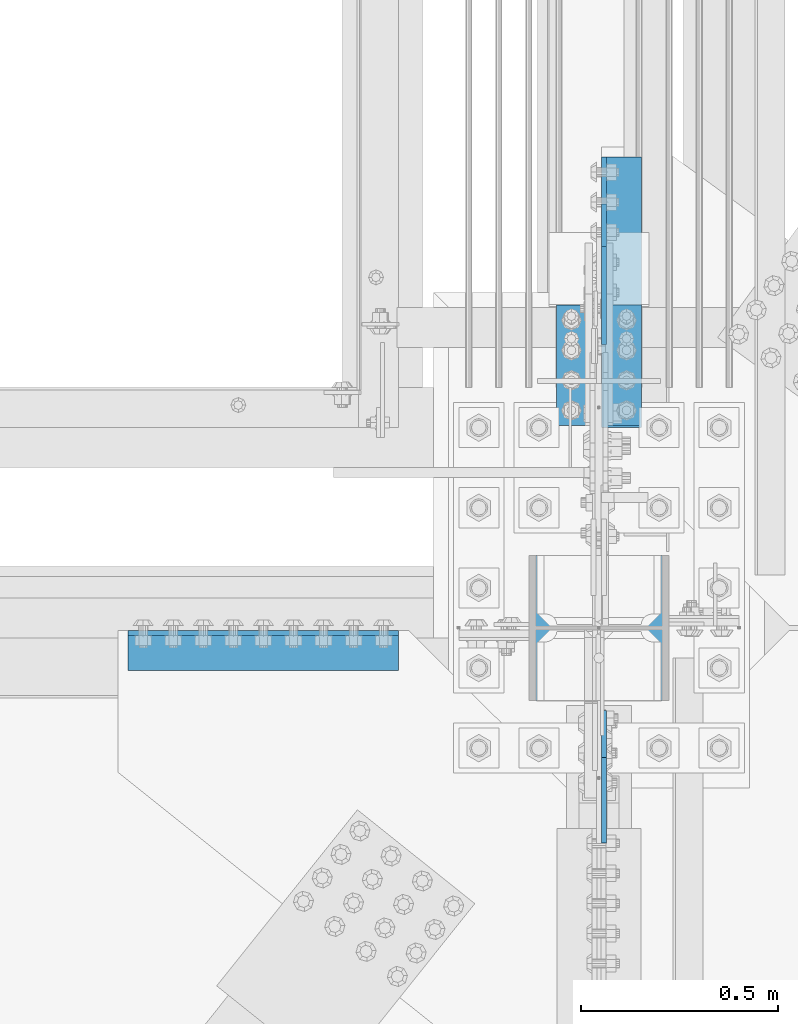
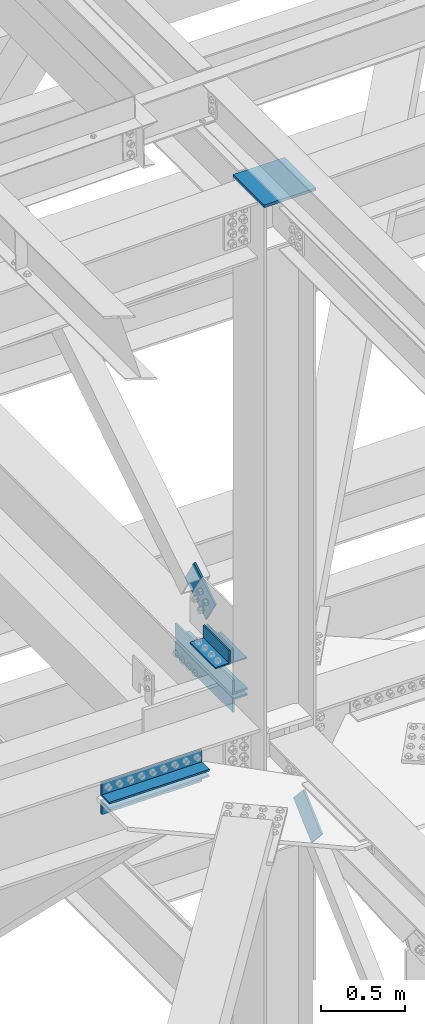
# One storey, part 2546 of 3843: 7 beams, 2 members, 7 elements without a shape of their own.
"""IFC2X3 building model written with IfcOpenShell, lengths in millimetres."""

from ifc_helpers import new_model, si_unit, frame, origin_with_axes, place, context, subcontext, project, spatial, faceted_brep, material, type_object, element, aggregate, save


model = new_model("IFC2X3")

# Units and contexts
model_context = context("Model", 3, precision=1e-05, world=origin_with_axes())
body_context = subcontext(model_context, "Body", "Model", "MODEL_VIEW")
ifc_project = project(units=[si_unit("LENGTHUNIT", "METRE", prefix="MILLI"), si_unit("AREAUNIT", "SQUARE_METRE"), si_unit("VOLUMEUNIT", "CUBIC_METRE"), si_unit("MASSUNIT", "GRAM", prefix="KILO"), si_unit("TIMEUNIT", "SECOND"), si_unit("PLANEANGLEUNIT", "RADIAN"), si_unit("SOLIDANGLEUNIT", "STERADIAN"), si_unit("THERMODYNAMICTEMPERATUREUNIT", "DEGREE_CELSIUS"), si_unit("LUMINOUSINTENSITYUNIT", "LUMEN")], contexts=[model_context])

# Site, building, storey
site_placement = place(None, origin_with_axes())
site = spatial("IfcSite", under=ifc_project, at=site_placement, CompositionType="ELEMENT")
building_placement = place(site_placement, origin_with_axes())
building = spatial("IfcBuilding", under=site, at=building_placement, Name="Undefined", CompositionType="ELEMENT")
storey_placement = place(building_placement, origin_with_axes())
storey = spatial("IfcBuildingStorey", under=building, at=storey_placement, Name="Undefined", CompositionType="ELEMENT", Elevation=0.0)

# Assembly, beam
assembly_1_placement = place(storey_placement, origin_with_axes())
assembly_1 = element("IfcElementAssembly", 1, at=assembly_1_placement, inside=storey, Name="ANGLE", AssemblyPlace="NOTDEFINED", PredefinedType="RIGID_FRAME")
ifc_material = material(Name="STEEL/A572-50")
beam_type_1 = type_object("IfcBeamType", Name="L4X4X3/8", PredefinedType="NOTDEFINED")
beam_1_placement = place(assembly_1_placement, frame((77069.9500005026, 92728.2562499988, 42519.599999989), z_axis=(0.0, 0.0, 1.0), x_axis=(0.0, 1.0, 0.0)))
beam_1 = element("IfcBeam", 2, at=beam_1_placement, type_object=beam_type_1, material=ifc_material, Name="ANGLE", ObjectType="L4X4X3/8", context=body_context, shape_type="Brep", body=[
    faceted_brep([(0.0, 50.8000000000029, -50.8000000000029), (0.0, 50.8000000000029, 50.8000000000029), (304.800000000003, 50.8000000000029, 50.8000000000029), (304.800000000003, 50.8000000000029, -50.8000000000029), (0.0, 41.2750000000015, 50.8000000000029), (304.800000000003, 41.2749999999942, 50.8000000000029), (0.0, 41.2749999999942, -41.2750000000015), (304.800000000003, 41.2749999999942, -41.2750000000015), (0.0, -50.8000000000029, -41.2750000000015), (304.800000000003, -50.8000000000029, -41.2750000000015), (0.0, -50.8000000000029, -50.8000000000029), (304.800000000003, -50.8000000000029, -50.8000000000029)], [[[0, 1, 2, 3]], [[1, 4, 5, 2]], [[4, 6, 7, 5]], [[6, 8, 9, 7]], [[8, 10, 11, 9]], [[10, 0, 3, 11]], [[5, 7, 9, 11, 3, 2]], [[10, 8, 6, 4, 1, 0]]]),
])
aggregate(assembly_1, [beam_1])

assembly_2_placement = place(storey_placement, origin_with_axes())
assembly_2 = element("IfcElementAssembly", 3, at=assembly_2_placement, inside=storey, Name="ANGLE", AssemblyPlace="NOTDEFINED", PredefinedType="RIGID_FRAME")
beam_2_placement = place(assembly_2_placement, frame((76955.6500005026, 93033.0562499988, 42519.5999999779), z_axis=(0.0, 0.0, 1.0), x_axis=(0.0, -1.0, 0.0)))
beam_2 = element("IfcBeam", 4, at=beam_2_placement, type_object=beam_type_1, material=ifc_material, Name="ANGLE", ObjectType="L4X4X3/8", context=body_context, shape_type="Brep", body=[
    faceted_brep([(0.0, 50.8000000000029, -50.8000000000029), (0.0, 50.8000000000029, 50.8000000000029), (304.800000000003, 50.8000000000029, 50.8000000000029), (304.800000000003, 50.8000000000029, -50.8000000000029), (0.0, 41.2750000000015, 50.8000000000029), (304.800000000003, 41.2749999999942, 50.8000000000029), (0.0, 41.2749999999942, -41.2750000000015), (304.800000000003, 41.2749999999942, -41.2750000000015), (0.0, -50.8000000000029, -41.2750000000015), (304.800000000003, -50.8000000000029, -41.2750000000015), (0.0, -50.8000000000029, -50.8000000000029), (304.800000000003, -50.8000000000029, -50.8000000000029)], [[[0, 1, 2, 3]], [[1, 4, 5, 2]], [[4, 6, 7, 5]], [[6, 8, 9, 7]], [[8, 10, 11, 9]], [[10, 0, 3, 11]], [[5, 7, 9, 11, 3, 2]], [[10, 8, 6, 4, 1, 0]]]),
])
aggregate(assembly_2, [beam_2])

# Assembly, beams
assembly_3_placement = place(storey_placement, origin_with_axes())
assembly_3 = element("IfcElementAssembly", 5, at=assembly_3_placement, inside=storey, Name="PLATE", AssemblyPlace="NOTDEFINED", PredefinedType="RIGID_FRAME")
beam_type_2 = type_object("IfcBeamType", Name="L4X4X1/2", PredefinedType="NOTDEFINED")
beam_3_placement = place(assembly_3_placement, frame((76504.8, 92157.550000002, 42297.35), z_axis=(0.0, -1.0, 0.0), x_axis=(-1.0, 0.0, 0.0)))
beam_3 = element("IfcBeam", 6, at=beam_3_placement, type_object=beam_type_2, material=ifc_material, Name="ANGLE", ObjectType="L4X4X1/2", context=body_context, shape_type="Brep", body=[
    faceted_brep([(0.0, 50.8000000000029, -50.8000000000029), (0.0, 50.8000000000029, 50.8000000000029), (685.800000000003, 50.8000000000029, 50.8000000000029), (685.800000000003, 50.8000000000029, -50.8000000000029), (0.0, 38.0999999999985, 50.8000000000029), (685.800000000003, 38.0999999999985, 50.8000000000029), (0.0, 38.0999999999985, -38.0999999999985), (685.800000000003, 38.0999999999985, -38.1000000000058), (0.0, -50.8000000000029, -38.1000000000058), (685.800000000003, -50.8000000000029, -38.1000000000058), (0.0, -50.8000000000029, -50.8000000000029), (685.800000000003, -50.8000000000029, -50.8000000000029)], [[[0, 1, 2, 3]], [[1, 4, 5, 2]], [[4, 6, 7, 5]], [[6, 8, 9, 7]], [[8, 10, 11, 9]], [[10, 0, 3, 11]], [[5, 7, 9, 11, 3, 2]], [[10, 8, 6, 4, 1, 0]]]),
])
beam_4_placement = place(assembly_3_placement, frame((75819.0, 92157.550000002, 42167.175), z_axis=(0.0, -1.0, 0.0), x_axis=(1.0, 0.0, 0.0)))
beam_4 = element("IfcBeam", 7, at=beam_4_placement, type_object=beam_type_2, material=ifc_material, Name="ANGLE", ObjectType="L4X4X1/2", context=body_context, shape_type="Brep", body=[
    faceted_brep([(0.0, 50.8000000000029, -50.8000000000029), (0.0, 50.8000000000029, 50.8000000000029), (685.800000000003, 50.8000000000029, 50.8000000000029), (685.800000000003, 50.8000000000029, -50.8000000000029), (0.0, 38.0999999999985, 50.8000000000029), (685.800000000003, 38.0999999999985, 50.8000000000029), (0.0, 38.0999999999985, -38.0999999999985), (685.800000000003, 38.0999999999985, -38.1000000000058), (0.0, -50.8000000000029, -38.1000000000058), (685.800000000003, -50.8000000000029, -38.1000000000058), (0.0, -50.8000000000029, -50.8000000000029), (685.800000000003, -50.8000000000029, -50.8000000000029)], [[[0, 1, 2, 3]], [[1, 4, 5, 2]], [[4, 6, 7, 5]], [[6, 8, 9, 7]], [[8, 10, 11, 9]], [[10, 0, 3, 11]], [[5, 7, 9, 11, 3, 2]], [[10, 8, 6, 4, 1, 0]]]),
])
aggregate(assembly_3, [beam_3, beam_4])

assembly_4_placement = place(storey_placement, origin_with_axes())
assembly_4 = element("IfcElementAssembly", 8, at=assembly_4_placement, inside=storey, Name="PLATE", AssemblyPlace="NOTDEFINED", PredefinedType="RIGID_FRAME")
beam_5_placement = place(assembly_4_placement, frame((77069.9500000263, 93408.4999999983, 42297.3500007629), z_axis=(1.0, 0.0, 0.0), x_axis=(0.0, -1.0, 0.0)))
beam_5 = element("IfcBeam", 9, at=beam_5_placement, type_object=beam_type_2, material=ifc_material, Name="ANGLE", ObjectType="L4X4X1/2", context=body_context, shape_type="Brep", body=[
    faceted_brep([(0.0, 50.8000000000029, -50.8000000000029), (0.0, 50.8000000000029, 50.8000000000029), (685.800000000003, 50.8000000000029, 50.8000000000029), (685.800000000003, 50.8000000000029, -50.8000000000029), (0.0, 38.0999999999985, 50.8000000000029), (685.800000000003, 38.0999999999985, 50.8000000000029), (0.0, 38.0999999999985, -38.0999999999985), (685.800000000003, 38.0999999999985, -38.1000000000058), (0.0, -50.8000000000029, -38.1000000000058), (685.800000000003, -50.8000000000029, -38.1000000000058), (0.0, -50.8000000000029, -50.8000000000029), (685.800000000003, -50.8000000000029, -50.8000000000029)], [[[0, 1, 2, 3]], [[1, 4, 5, 2]], [[4, 6, 7, 5]], [[6, 8, 9, 7]], [[8, 10, 11, 9]], [[10, 0, 3, 11]], [[5, 7, 9, 11, 3, 2]], [[10, 8, 6, 4, 1, 0]]]),
])
beam_6_placement = place(assembly_4_placement, frame((77069.9500000064, 92722.6999999983, 42167.175), z_axis=(1.0, 0.0, 0.0), x_axis=(0.0, 1.0, 0.0)))
beam_6 = element("IfcBeam", 10, at=beam_6_placement, type_object=beam_type_2, material=ifc_material, Name="ANGLE", ObjectType="L4X4X1/2", context=body_context, shape_type="Brep", body=[
    faceted_brep([(0.0, 50.8000000000029, -50.8000000000029), (0.0, 50.8000000000029, 50.8000000000029), (685.800000000003, 50.8000000000029, 50.8000000000029), (685.800000000003, 50.8000000000029, -50.8000000000029), (0.0, 38.0999999999985, 50.8000000000029), (685.800000000003, 38.0999999999985, 50.8000000000029), (0.0, 38.0999999999985, -38.0999999999985), (685.800000000003, 38.0999999999985, -38.1000000000058), (0.0, -50.8000000000029, -38.1000000000058), (685.800000000003, -50.8000000000029, -38.1000000000058), (0.0, -50.8000000000029, -50.8000000000029), (685.800000000003, -50.8000000000029, -50.8000000000029)], [[[0, 1, 2, 3]], [[1, 4, 5, 2]], [[4, 6, 7, 5]], [[6, 8, 9, 7]], [[8, 10, 11, 9]], [[10, 0, 3, 11]], [[5, 7, 9, 11, 3, 2]], [[10, 8, 6, 4, 1, 0]]]),
])
aggregate(assembly_4, [beam_5, beam_6])

# Assembly, member
assembly_5_placement = place(storey_placement, origin_with_axes())
assembly_5 = element("IfcElementAssembly", 11, at=assembly_5_placement, inside=storey, AssemblyPlace="NOTDEFINED", PredefinedType="RIGID_FRAME")
member_type_1 = type_object("IfcMemberType", PredefinedType="NOTDEFINED")
member_1_placement = place(assembly_5_placement, frame((77025.5000005026, 92987.7734139596, 42681.8875327999), z_axis=(0.0, 0.531085498200757, -0.847318236320247), x_axis=(0.0, 0.847318236320259, 0.531085498200737)))
member_1 = element("IfcMember", 12, at=member_1_placement, type_object=member_type_1, material=ifc_material, Name="PLATE", context=body_context, shape_type="Brep", body=[
    faceted_brep([(1.74622982740402e-10, 6.35000000000582, -101.600000000195), (-1.67347025126219e-10, 6.35000000000582, 101.600000000151), (292.1000000028, 6.35000000000582, 101.600000000661), (292.100000003156, 6.35000000000582, -101.599999999686), (-1.67347025126219e-10, -6.35000000000582, 101.600000000151), (292.1000000028, -6.35000000000582, 101.600000000661), (1.74622982740402e-10, -6.35000000000582, -101.600000000195), (292.100000003156, -6.35000000000582, -101.599999999686)], [[[0, 1, 2, 3]], [[1, 4, 5, 2]], [[4, 6, 7, 5]], [[6, 0, 3, 7]], [[5, 7, 3, 2]], [[6, 4, 1, 0]]]),
])
aggregate(assembly_5, [member_1])

assembly_6_placement = place(storey_placement, origin_with_axes())
assembly_6 = element("IfcElementAssembly", 13, at=assembly_6_placement, inside=storey, AssemblyPlace="NOTDEFINED", PredefinedType="RIGID_FRAME")
member_type_2 = type_object("IfcMemberType", PredefinedType="NOTDEFINED")
member_2_placement = place(assembly_6_placement, frame((77025.4999997492, 91945.6025842794, 42001.439751468), z_axis=(0.0, -0.673388817040846, 0.739288510044847), x_axis=(0.0, -0.73928851004485, -0.673388817040843)))
member_2 = element("IfcMember", 14, at=member_2_placement, type_object=member_type_2, material=ifc_material, Name="PLATE", context=body_context, shape_type="Brep", body=[
    faceted_brep([(1.45519152283669e-11, 6.35000000000582, -88.8999999998996), (0.0, 6.34999999999854, 88.9000015258789), (292.099999998526, 6.35000000000582, 88.900000000016), (292.099999999057, 6.35000000000582, -88.8999999997031), (0.0, -6.34999999999854, 88.9000015258789), (292.099999998526, -6.35000000000582, 88.900000000016), (1.45519152283669e-11, -6.35000000000582, -88.8999999998996), (292.099999999057, -6.35000000000582, -88.8999999997031)], [[[0, 1, 2, 3]], [[1, 4, 5, 2]], [[4, 6, 7, 5]], [[6, 0, 3, 7]], [[5, 7, 3, 2]], [[6, 4, 1, 0]]]),
])
aggregate(assembly_6, [member_2])

# Assembly, beam
assembly_7_placement = place(storey_placement, origin_with_axes())
assembly_7 = element("IfcElementAssembly", 15, at=assembly_7_placement, inside=storey, Name="COLUMN", AssemblyPlace="NOTDEFINED", PredefinedType="RIGID_FRAME")
beam_type_3 = type_object("IfcBeamType", PredefinedType="NOTDEFINED")
beam_7_placement = place(assembly_7_placement, frame((77190.6, 92214.7, 46264.3645639882), z_axis=(0.0, 1.0, 0.0), x_axis=(-1.0, 0.0, 0.0)))
beam_7 = element("IfcBeam", 16, at=beam_7_placement, type_object=beam_type_3, material=ifc_material, Name="PLATE", context=body_context, shape_type="Brep", body=[
    faceted_brep([(0.0, 9.52500000000146, -184.150000000001), (0.0, 9.52500000000146, 184.150000000001), (355.600000000006, 9.52500000000146, 184.150000000001), (355.600000000006, 9.52500000000146, -184.150000000001), (0.0, -9.52500000000146, 184.150000000001), (355.600000000006, -9.52500000000146, 184.150000000001), (0.0, -9.52500000000146, -184.150000000001), (355.600000000006, -9.52500000000146, -184.150000000001)], [[[0, 1, 2, 3]], [[1, 4, 5, 2]], [[4, 6, 7, 5]], [[6, 0, 3, 7]], [[5, 7, 3, 2]], [[6, 4, 1, 0]]]),
])
aggregate(assembly_7, [beam_7])

save(model, "model.ifc")
